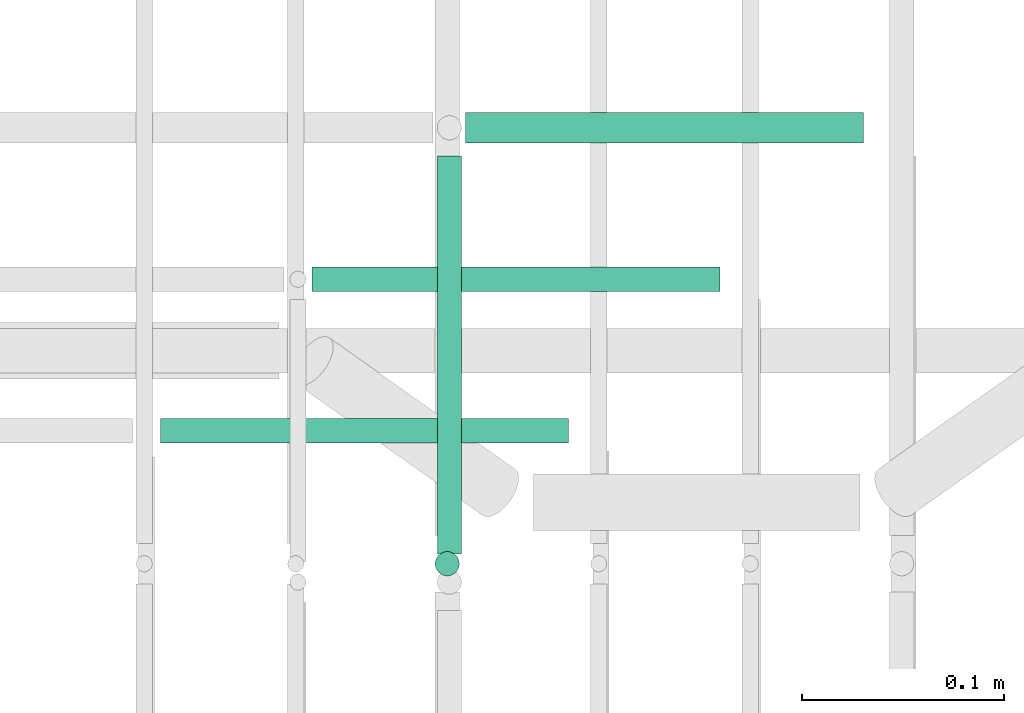
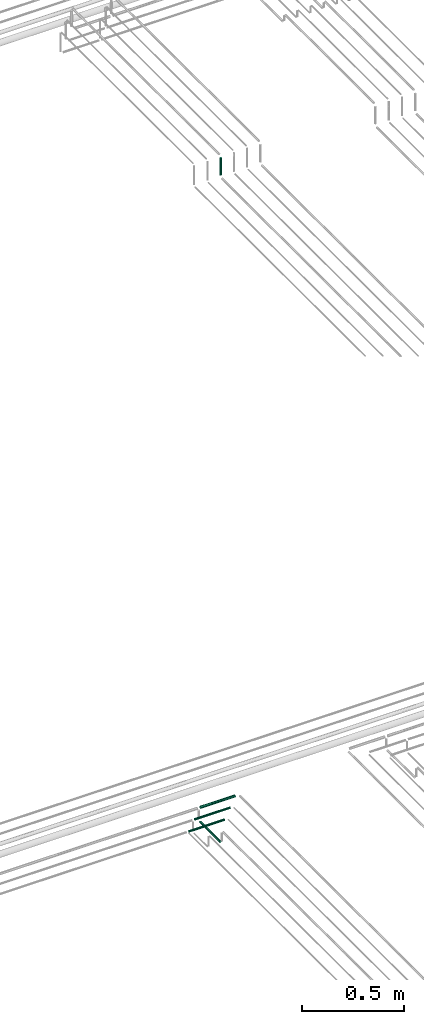
# One storey, part 185 of 331: 5 flow segments.
"""IFC2X3 building model written with IfcOpenShell, lengths in millimetres."""

from ifc_helpers import new_model, entity, si_unit, converted_unit, derived_unit, direction, frame, frame_2d, origin, origin_2d_with_axis, place, context, subcontext, project, spatial, circle, extrude, type_object, element, save


model = new_model("IFC2X3")

# Units and contexts
model_context = context("Model", 3, precision=0.01, world=origin(), true_north=direction((6.12303176911189e-17, 1.0)))
body_context = subcontext(model_context, "Body", "Model", "MODEL_VIEW")
ifc_project = project(units=[si_unit("LENGTHUNIT", "METRE", prefix="MILLI"), si_unit("AREAUNIT", "SQUARE_METRE"), si_unit("VOLUMEUNIT", "CUBIC_METRE"), converted_unit("PLANEANGLEUNIT", "DEGREE", entity("IfcRatioMeasure", 0.0174532925199433), si_unit("PLANEANGLEUNIT", "RADIAN"), dimensions=[0, 0, 0, 0, 0, 0, 0]), si_unit("MASSUNIT", "GRAM", prefix="KILO"), derived_unit("MASSDENSITYUNIT", [(si_unit("MASSUNIT", "GRAM", prefix="KILO"), 1), (si_unit("LENGTHUNIT", "METRE"), -3)]), derived_unit("MOMENTOFINERTIAUNIT", [(si_unit("LENGTHUNIT", "METRE"), 4)]), si_unit("TIMEUNIT", "SECOND"), si_unit("FREQUENCYUNIT", "HERTZ"), si_unit("THERMODYNAMICTEMPERATUREUNIT", "DEGREE_CELSIUS"), derived_unit("THERMALTRANSMITTANCEUNIT", [(si_unit("MASSUNIT", "GRAM", prefix="KILO"), 1), (si_unit("THERMODYNAMICTEMPERATUREUNIT", "KELVIN"), -1), (si_unit("TIMEUNIT", "SECOND"), -3)]), derived_unit("VOLUMETRICFLOWRATEUNIT", [(si_unit("LENGTHUNIT", "METRE"), 3), (si_unit("TIMEUNIT", "SECOND"), -1)]), derived_unit("MASSFLOWRATEUNIT", [(si_unit("MASSUNIT", "GRAM", prefix="KILO"), 1), (si_unit("TIMEUNIT", "SECOND"), -1)]), derived_unit("ROTATIONALFREQUENCYUNIT", [(si_unit("TIMEUNIT", "SECOND"), -1)]), si_unit("ELECTRICCURRENTUNIT", "AMPERE"), si_unit("ELECTRICVOLTAGEUNIT", "VOLT"), si_unit("POWERUNIT", "WATT"), si_unit("FORCEUNIT", "NEWTON", prefix="KILO"), si_unit("ILLUMINANCEUNIT", "LUX"), si_unit("LUMINOUSFLUXUNIT", "LUMEN"), si_unit("LUMINOUSINTENSITYUNIT", "CANDELA"), derived_unit("USERDEFINED", [(si_unit("MASSUNIT", "GRAM", prefix="KILO"), -1), (si_unit("LENGTHUNIT", "METRE"), -2), (si_unit("TIMEUNIT", "SECOND"), 3), (si_unit("LUMINOUSFLUXUNIT", "LUMEN"), 1)]), derived_unit("LINEARVELOCITYUNIT", [(si_unit("LENGTHUNIT", "METRE"), 1), (si_unit("TIMEUNIT", "SECOND"), -1)]), si_unit("PRESSUREUNIT", "PASCAL"), derived_unit("USERDEFINED", [(si_unit("LENGTHUNIT", "METRE"), -2), (si_unit("MASSUNIT", "GRAM", prefix="KILO"), 1), (si_unit("TIMEUNIT", "SECOND"), -2)]), derived_unit("LINEARFORCEUNIT", [(si_unit("MASSUNIT", "GRAM", prefix="KILO"), 1), (si_unit("LENGTHUNIT", "METRE"), 1), (si_unit("TIMEUNIT", "SECOND"), -2), (si_unit("LENGTHUNIT", "METRE"), -1)]), derived_unit("PLANARFORCEUNIT", [(si_unit("MASSUNIT", "GRAM", prefix="KILO"), 1), (si_unit("LENGTHUNIT", "METRE"), 1), (si_unit("TIMEUNIT", "SECOND"), -2), (si_unit("LENGTHUNIT", "METRE"), -2)])], contexts=[model_context])

# Site, building, storey
site_placement = place(None, frame((0.0, -0.00077364408347762, 0.0)))
site = spatial("IfcSite", under=ifc_project, at=site_placement, CompositionType="ELEMENT")
building_placement = place(site_placement, origin())
building = spatial("IfcBuilding", under=site, at=building_placement, CompositionType="ELEMENT")
storey_placement = place(building_placement, origin())
storey = spatial("IfcBuildingStorey", under=building, at=storey_placement, CompositionType="ELEMENT", Elevation=0.0)

# Flow segments
pipe_segment_type = type_object("IfcPipeSegmentType", PredefinedType="NOTDEFINED")
flow_segment_1_placement = place(storey_placement, frame((43613.5132590561, 8095.00994384932, 14467.4047277641)))
element("IfcFlowSegment", 1, at=flow_segment_1_placement, inside=storey, type_object=pipe_segment_type, context=body_context, shape_type="SweptSolid", body=[
    extrude(circle(Radius=6.0, at=origin_2d_with_axis()), frame((7.59527223591454, 0.0, 7.5952722359167), z_axis=(0.0, 1.0, 0.0), x_axis=(1.0, 0.0, 0.0)), (0.0, 0.0, 1.0), 197.000000000006),
])
flow_segment_2_placement = place(storey_placement, frame((43478.108531292, 8148.41467161339, 14542.4047277641)))
element("IfcFlowSegment", 2, at=flow_segment_2_placement, inside=storey, type_object=pipe_segment_type, context=body_context, shape_type="SweptSolid", body=[
    extrude(circle(Radius=6.0, at=frame_2d((4.33146851719357e-12, 0.0), x_axis=(1.0, 0.0))), frame((0.0, 7.59527223591995, 7.5952722359167), z_axis=(1.0, 0.0, 0.0), x_axis=(0.0, 1.0, 0.0)), (0.0, 0.0, 1.0), 202.000000000015),
])
flow_segment_3_placement = place(storey_placement, frame((43553.1085352132, 8223.41467161341, 14542.4036514368)))
element("IfcFlowSegment", 3, at=flow_segment_3_placement, inside=storey, type_object=pipe_segment_type, context=body_context, shape_type="SweptSolid", body=[
    extrude(circle(Radius=6.0, at=frame_2d((-1.08286712929839e-12, 2.16573425859679e-12), x_axis=(1.0, 0.0))), frame((0.0, 7.5952722359167, 7.59527223591454), z_axis=(1.0, 0.0, 0.0), x_axis=(0.0, 1.0, 0.0)), (0.0, 0.0, 1.0), 201.999996078927),
])
flow_segment_4_placement = place(storey_placement, frame((43629.1085268785, 8296.9146716134, 14540.9042766085)))
element("IfcFlowSegment", 4, at=flow_segment_4_placement, inside=storey, type_object=pipe_segment_type, context=body_context, shape_type="SweptSolid", body=[
    extrude(circle(Radius=7.5, at=frame_2d((-1.08286712929839e-12, 7.78132442118943e-31), x_axis=(1.0, 0.0))), frame((0.0, 9.09527223591744, 9.09527223591636), z_axis=(1.0, 0.0, 0.0), x_axis=(0.0, 1.0, 0.0)), (0.0, 0.0, 1.0), 197.000004409997),
])
flow_segment_5_placement = place(building_placement, frame((43612.4468045266, 8082.55353441903, 18464.0)))
element("IfcFlowSegment", 5, at=flow_segment_5_placement, inside=storey, type_object=pipe_segment_type, context=body_context, shape_type="SweptSolid", body=[
    extrude(circle(Radius=6.0, at=origin_2d_with_axis()), frame((7.59527223591454, 7.59527223591562, 0.0), z_axis=(0.0, 0.0, 1.0), x_axis=(-1.0, 0.0, 0.0)), (0.0, 0.0, 1.0), 102.000000000014),
])

save(model, "model.ifc")
